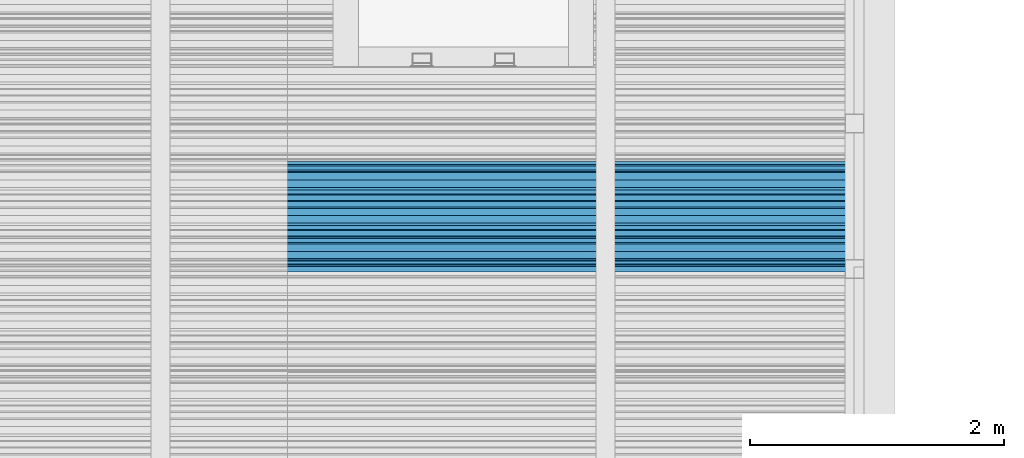
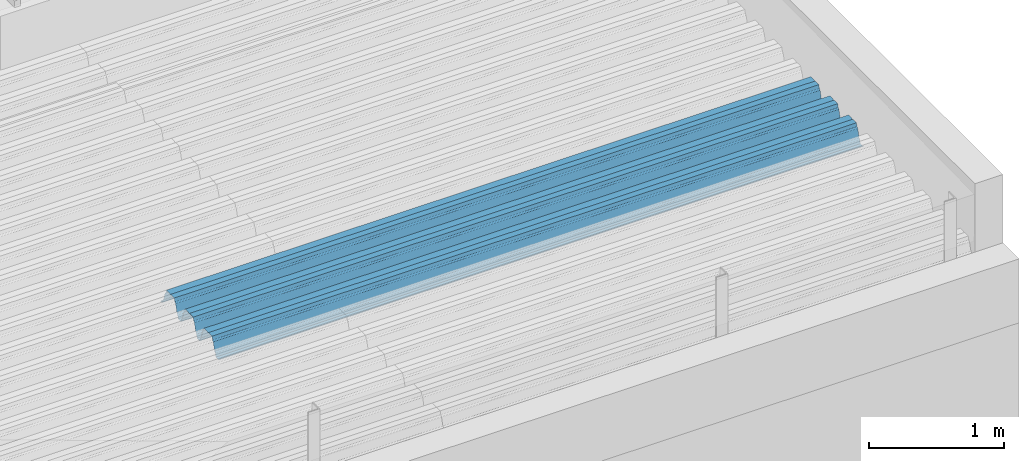
# One storey, part 39 of 153: 1 beam, 1 element without a shape of its own.
"""IFC2X3 building model written with IfcOpenShell, lengths in millimetres."""

from ifc_helpers import new_model, si_unit, frame, origin_with_axes, place, context, subcontext, project, spatial, faceted_brep, material, type_object, element, aggregate, save


model = new_model("IFC2X3")

# Units and contexts
model_context = context("Model", 3, precision=1e-05, world=origin_with_axes())
body_context = subcontext(model_context, "Body", "Model", "MODEL_VIEW")
ifc_project = project(units=[si_unit("LENGTHUNIT", "METRE", prefix="MILLI"), si_unit("AREAUNIT", "SQUARE_METRE"), si_unit("VOLUMEUNIT", "CUBIC_METRE"), si_unit("MASSUNIT", "GRAM", prefix="KILO"), si_unit("TIMEUNIT", "SECOND"), si_unit("PLANEANGLEUNIT", "RADIAN"), si_unit("SOLIDANGLEUNIT", "STERADIAN"), si_unit("THERMODYNAMICTEMPERATUREUNIT", "DEGREE_CELSIUS"), si_unit("LUMINOUSINTENSITYUNIT", "LUMEN")], contexts=[model_context])

# Site, building, storey
site_placement = place(None, origin_with_axes())
site = spatial("IfcSite", under=ifc_project, at=site_placement, CompositionType="ELEMENT")
building_placement = place(site_placement, origin_with_axes())
building = spatial("IfcBuilding", under=site, at=building_placement, CompositionType="ELEMENT")
storey_placement = place(building_placement, origin_with_axes())
storey = spatial("IfcBuildingStorey", under=building, at=storey_placement, Name="8", CompositionType="ELEMENT", Elevation=0.0)

# Assembly, beam
assembly_placement = place(storey_placement, origin_with_axes())
assembly = element("IfcElementAssembly", 1, at=assembly_placement, inside=storey, Name="Steel Assembly", AssemblyPlace="NOTDEFINED", PredefinedType="RIGID_FRAME")
ifc_material = material(Name="STEEL/S355J2")
beam_type = type_object("IfcBeamType", Name="W", PredefinedType="NOTDEFINED")
beam_placement = place(assembly_placement, frame((21782.0, 17045.0793818776, 105770.648873072), z_axis=(0.0, -0.0124990270013869, 0.999921884110963), x_axis=(-1.0, 3.00000001838171e-08, 0.0)))
beam = element("IfcBeam", 2, at=beam_placement, type_object=beam_type, material=ifc_material, ObjectType="W", context=body_context, shape_type="Brep", body=[
    faceted_brep([(0.0, -412.839996337891, -77.0100021362159), (0.0, -409.160003662109, -77.0100021362014), (5530.0, -409.160003662109, -77.0100021362014), (5530.0, -412.839996337891, -77.0100021362159), (0.0, -408.070007324222, -73.4800033569045), (5530.0, -408.070007324222, -73.4800033569045), (0.0, -400.339996337894, -48.0600013732619), (5530.0, -400.339996337894, -48.0600013732619), (0.0, -399.459991455082, -46.5600013732619), (5530.0, -399.459991455082, -46.5600013732619), (0.0, -390.329986572269, -36.5499992370314), (5530.0, -390.329986572269, -36.5499992370314), (0.0, -389.19000244141, -34.6300010680861), (5530.0, -389.19000244141, -34.6300010680861), (0.0, -367.820007324222, 35.3400001526024), (5530.0, -367.820007324222, 35.3400001526024), (0.0, -366.989990234379, 36.8499984741502), (5530.0, -366.989990234379, 36.8499984741502), (0.0, -357.809997558597, 46.8600006103807), (5530.0, -357.809997558597, 46.8600006103807), (0.0, -356.720001220707, 48.7700004577782), (5530.0, -356.720001220707, 48.7700004577782), (0.0, -349.309997558594, 73.1500015258935), (5530.0, -349.309997558594, 73.1500015258935), (0.0, -347.850006103516, 75.2300033569481), (5530.0, -347.850006103516, 75.2300033569481), (0.0, -345.470001220707, 76.010002136245), (5530.0, -345.470001220707, 76.010002136245), (0.0, -305.480010986332, 76.010002136245), (5530.0, -305.480010986332, 76.010002136245), (0.0, -304.279998779301, 75.8000030517578), (5530.0, -304.279998779301, 75.8000030517578), (0.0, -291.679992675785, 71.6999969482567), (5530.0, -291.679992675785, 71.6999969482567), (0.0, -290.179992675789, 71.2300033569481), (5530.0, -290.179992675789, 71.2300033569481), (0.0, -288.720001220707, 71.6999969482567), (5530.0, -288.720001220707, 71.6999969482567), (0.0, -276.119995117191, 75.8000030517869), (5530.0, -276.119995117191, 75.8000030517869), (0.0, -274.929992675785, 76.010002136245), (5530.0, -274.929992675785, 76.010002136245), (0.0, -234.94000244141, 76.010002136245), (5530.0, -234.94000244141, 76.010002136245), (0.0, -232.550003051758, 75.2300033569627), (5530.0, -232.550003051758, 75.2300033569627), (0.0, -231.100006103519, 73.1500015258935), (5530.0, -231.100006103519, 73.1500015258935), (0.0, -223.679992675785, 48.7700004577782), (5530.0, -223.679992675785, 48.7700004577782), (0.0, -222.589996337894, 46.8600006103661), (5530.0, -222.589996337894, 46.8600006103661), (0.0, -213.410003662113, 36.8499984741502), (5530.0, -213.410003662113, 36.8499984741502), (0.0, -212.529998779301, 35.3400001526024), (5530.0, -212.529998779301, 35.3400001526024), (0.0, -191.160003662109, -34.6300010681007), (5530.0, -191.160003662109, -34.6300010681007), (0.0, -190.070007324222, -36.5499992370605), (5530.0, -190.070007324222, -36.5499992370605), (0.0, -180.940002441406, -46.560001373291), (5530.0, -180.940002441406, -46.560001373291), (0.0, -180.059997558597, -48.0600013732619), (5530.0, -180.059997558597, -48.0600013732619), (0.0, -172.330001831055, -73.480003356919), (5530.0, -172.330001831055, -73.480003356919), (0.0, -171.240005493168, -77.0100021362159), (5530.0, -171.240005493168, -77.0100021362159), (0.0, -129.330001831062, -77.0100021362014), (5530.0, -129.330001831062, -77.0100021362014), (0.0, -128.300003051761, -73.480003356919), (5530.0, -128.300003051761, -73.480003356919), (0.0, -120.51999664307, -48.0600013732765), (5530.0, -120.51999664307, -48.0600013732765), (0.0, -119.629997253418, -46.5600013732765), (5530.0, -119.629997253418, -46.5600013732765), (0.0, -110.500000000004, -36.5499992370314), (5530.0, -110.500000000004, -36.5499992370314), (0.0, -109.419998168949, -34.6300010680861), (5530.0, -109.419998168949, -34.6300010680861), (0.0, -88.0500030517615, 35.3400001526024), (5530.0, -88.0500030517615, 35.3400001526024), (0.0, -87.160003662113, 36.8499984741356), (5530.0, -87.160003662113, 36.8499984741356), (0.0, -78.0400009155273, 46.8600006103807), (5530.0, -78.0400009155273, 46.8600006103807), (0.0, -76.8899993896557, 48.7700004577782), (5530.0, -76.8899993896557, 48.7700004577782), (0.0, -69.4800033569336, 73.1500015258935), (5530.0, -69.4800033569336, 73.1500015258935), (0.0, -68.0299987793042, 75.2300033569336), (5530.0, -68.0299987793042, 75.2300033569336), (0.0, -65.6399993896521, 76.010002136245), (5530.0, -65.6399993896521, 76.010002136245), (0.0, -25.6499996185375, 76.0100021362596), (5530.0, -25.6499996185375, 76.0100021362596), (0.0, -24.5100002288891, 75.8000030517724), (5530.0, -24.5100002288891, 75.8000030517724), (0.0, -11.8500003814697, 71.6999969482567), (5530.0, -11.8500003814697, 71.6999969482567), (0.0, -10.3999996185339, 71.2300033569481), (5530.0, -10.3999996185339, 71.2300033569481), (0.0, -8.89999961853391, 71.6999969482567), (5530.0, -8.89999961853391, 71.6999969482567), (0.0, 3.71000003814333, 75.8000030517724), (5530.0, 3.71000003814333, 75.8000030517724), (0.0, 4.90000009536379, 76.0100021362596), (5530.0, 4.90000009536379, 76.0100021362596), (0.0, 44.8899993896484, 76.010002136245), (5530.0, 44.8899993896484, 76.010002136245), (0.0, 47.2799987792932, 75.2300033569481), (5530.0, 47.2799987792932, 75.2300033569481), (0.0, 48.6800003051721, 73.1500015258935), (5530.0, 48.6800003051721, 73.1500015258935), (0.0, 56.1500015258753, 48.7700004577782), (5530.0, 56.1500015258753, 48.7700004577782), (0.0, 57.2400016784632, 46.8600006103807), (5530.0, 57.2400016784632, 46.8600006103807), (0.0, 66.3700027465784, 36.8499984741211), (5530.0, 66.3700027465784, 36.8499984741211), (0.0, 67.2499999999964, 35.3400001526024), (5530.0, 67.2499999999964, 35.3400001526024), (0.0, 88.6200027465748, -34.6300010681007), (5530.0, 88.6200027465748, -34.6300010681007), (0.0, 89.709999084469, -36.549999237046), (5530.0, 89.709999084469, -36.549999237046), (0.0, 98.8899993896412, -46.5600013732765), (5530.0, 98.8899993896412, -46.5600013732765), (0.0, 99.7699966430628, -48.0600013732765), (5530.0, 99.7699966430628, -48.0600013732765), (0.0, 107.499999999996, -73.4800033569336), (5530.0, 107.499999999996, -73.4800033569336), (0.0, 108.589996337887, -77.0100021362014), (5530.0, 108.589996337887, -77.0100021362014), (0.0, 112.269996643063, -77.0100021362159), (5530.0, 112.269996643063, -77.0100021362159), (0.0, 146.759994506836, -77.0100021362159), (5530.0, 146.759994506836, -77.0100021362159), (0.0, 150.440002441403, -77.0100021362159), (5530.0, 150.440002441403, -77.0100021362159), (0.0, 151.529998779297, -73.480003356919), (5530.0, 151.529998779297, -73.480003356919), (0.0, 159.30999755859, -48.0600013732765), (5530.0, 159.30999755859, -48.0600013732765), (0.0, 160.190002441406, -46.5600013732619), (5530.0, 160.190002441406, -46.5600013732619), (0.0, 169.320007324215, -36.549999237046), (5530.0, 169.320007324215, -36.549999237046), (0.0, 170.410003662106, -34.6300010680861), (5530.0, 170.410003662106, -34.6300010680861), (0.0, 191.779998779293, 35.3400001526024), (5530.0, 191.779998779293, 35.3400001526024), (0.0, 192.660003662109, 36.8499984741502), (5530.0, 192.660003662109, 36.8499984741502), (0.0, 201.789993286129, 46.8600006103661), (5530.0, 201.789993286129, 46.8600006103661), (0.0, 202.880004882809, 48.7700004577637), (5530.0, 202.880004882809, 48.7700004577637), (0.0, 210.350006103512, 73.150001525908), (5530.0, 210.350006103512, 73.150001525908), (0.0, 211.800003051754, 75.2300033569481), (5530.0, 211.800003051754, 75.2300033569481), (0.0, 214.190002441406, 76.010002136245), (5530.0, 214.190002441406, 76.010002136245), (0.0, 254.179992675778, 76.010002136245), (5530.0, 254.179992675778, 76.010002136245), (0.0, 255.320007324215, 75.8000030517869), (5530.0, 255.320007324215, 75.8000030517869), (0.0, 267.980010986324, 71.6999969482713), (5530.0, 267.980010986324, 71.6999969482713), (0.0, 269.429992675778, 71.2300033569481), (5530.0, 269.429992675778, 71.2300033569481), (0.0, 270.880004882809, 71.6999969482567), (5530.0, 270.880004882809, 71.6999969482567), (0.0, 283.540008544918, 75.8000030517869), (5530.0, 283.540008544918, 75.8000030517869), (0.0, 284.679992675778, 76.010002136245), (5530.0, 284.679992675778, 76.010002136245), (0.0, 324.670013427731, 76.010002136245), (5530.0, 324.670013427731, 76.010002136245), (0.0, 327.049987792969, 75.2300033569627), (5530.0, 327.049987792969, 75.2300033569627), (0.0, 328.510009765625, 73.1500015258789), (5530.0, 328.510009765625, 73.1500015258789), (0.0, 335.980010986324, 48.7700004577782), (5530.0, 335.980010986324, 48.7700004577782), (0.0, 337.05999755859, 46.8600006103661), (5530.0, 337.05999755859, 46.8600006103661), (0.0, 346.190002441399, 36.8499984741356), (5530.0, 346.190002441399, 36.8499984741356), (0.0, 347.079986572266, 35.3400001526024), (5530.0, 347.079986572266, 35.3400001526024), (0.0, 368.450012207028, -34.6300010680861), (5530.0, 368.450012207028, -34.6300010680861), (0.0, 369.529998779293, -36.5499992370314), (5530.0, 369.529998779293, -36.5499992370314), (0.0, 378.660003662106, -46.5600013732619), (5530.0, 378.660003662106, -46.5600013732619), (0.0, 379.540008544918, -48.0600013732619), (5530.0, 379.540008544918, -48.0600013732619), (0.0, 387.329986572262, -73.480003356919), (5530.0, 387.329986572262, -73.480003356919), (0.0, 388.410003662109, -77.0100021362159), (5530.0, 388.410003662109, -77.0100021362159), (0.0, 392.100006103512, -77.0100021362159), (5530.0, 392.100006103512, -77.0100021362159), (0.0, 426.589996337887, -77.0100021362159), (5530.0, 426.589996337887, -77.0100021362159), (0.0, 430.269989013668, -77.0100021362159), (5530.0, 430.269989013668, -77.0100021362159), (0.0, 431.359985351559, -73.4800033569045), (5530.0, 431.359985351559, -73.4800033569045), (0.0, 433.179992675778, -67.5699996948097), (5530.0, 433.179992675778, -67.5699996948097), (0.0, 432.220001220699, -67.2699966430373), (5530.0, 432.220001220699, -67.2699966430373), (0.0, 430.410003662106, -73.1800003051612), (5530.0, 430.410003662106, -73.1800003051612), (0.0, 429.529998779293, -76.0100021362159), (5530.0, 429.529998779293, -76.0100021362159), (0.0, 426.589996337891, -76.0100021362159), (5530.0, 426.589996337891, -76.0100021362159), (0.0, 392.100006103512, -76.0100021362159), (5530.0, 392.100006103512, -76.0100021362159), (0.0, 389.149993896481, -76.0100021362014), (5530.0, 389.149993896481, -76.0100021362014), (0.0, 388.279998779293, -73.1800003051467), (5530.0, 388.279998779293, -73.1800003051467), (0.0, 380.470001220699, -47.659999847383), (5530.0, 380.470001220699, -47.659999847383), (0.0, 379.470001220699, -45.9599990844436), (5530.0, 379.470001220699, -45.9599990844436), (0.0, 370.350006103512, -35.9599990844581), (5530.0, 370.350006103512, -35.9599990844581), (0.0, 369.369995117184, -34.2299995422218), (5530.0, 369.369995117184, -34.2299995422218), (0.0, 347.999999999996, 35.7500000000146), (5530.0, 347.999999999996, 35.7500000000146), (0.0, 346.999999999996, 37.4399986267235), (5530.0, 346.999999999996, 37.4399986267235), (0.0, 337.880004882809, 47.450000762954), (5530.0, 337.880004882809, 47.450000762954), (0.0, 336.899993896481, 49.1699981689453), (5530.0, 336.899993896481, 49.1699981689453), (0.0, 329.420013427731, 73.5999984741356), (5530.0, 329.420013427731, 73.5999984741356), (0.0, 327.679992675781, 76.0699996948533), (5530.0, 327.679992675781, 76.0699996948533), (0.0, 324.829986572262, 77.010002136245), (5530.0, 324.829986572262, 77.010002136245), (0.0, 284.589996337887, 77.010002136245), (5530.0, 284.589996337887, 77.010002136245), (0.0, 283.290008544922, 76.769996643081), (5530.0, 283.290008544922, 76.769996643081), (0.0, 270.570007324215, 72.6500015258935), (5530.0, 270.570007324215, 72.6500015258935), (0.0, 269.429992675781, 72.2799987793114), (5530.0, 269.429992675781, 72.2799987793114), (0.0, 268.279998779293, 72.650001525908), (5530.0, 268.279998779293, 72.650001525908), (0.0, 255.570007324219, 76.769996643081), (5530.0, 255.570007324219, 76.769996643081), (0.0, 254.270004272461, 77.0100021362596), (5530.0, 254.270004272461, 77.0100021362596), (0.0, 214.029998779293, 77.0100021362596), (5530.0, 214.029998779293, 77.0100021362596), (0.0, 211.179992675781, 76.0699996948388), (5530.0, 211.179992675781, 76.0699996948388), (0.0, 209.440002441403, 73.5999984741356), (5530.0, 209.440002441403, 73.5999984741356), (0.0, 201.960006713864, 49.1699981689599), (5530.0, 201.960006713864, 49.1699981689599), (0.0, 200.979995727532, 47.450000762954), (5530.0, 200.979995727532, 47.450000762954), (0.0, 191.850006103508, 37.4399986267235), (5530.0, 191.850006103508, 37.4399986267235), (0.0, 190.860000610352, 35.7500000000146), (5530.0, 190.860000610352, 35.7500000000146), (0.0, 169.49000549316, -34.2299995422218), (5530.0, 169.49000549316, -34.2299995422218), (0.0, 168.509994506832, -35.9599990844581), (5530.0, 168.509994506832, -35.9599990844581), (0.0, 159.380004882805, -45.9599990844436), (5530.0, 159.380004882805, -45.9599990844436), (0.0, 158.389999389645, -47.6599998473976), (5530.0, 158.389999389645, -47.6599998473976), (0.0, 150.580001831051, -73.1800003051612), (5530.0, 150.580001831051, -73.1800003051612), (0.0, 149.710006713864, -76.0100021362159), (5530.0, 149.710006713864, -76.0100021362159), (0.0, 146.759994506836, -76.0100021362159), (5530.0, 146.759994506836, -76.0100021362159), (0.0, 112.269996643063, -76.0100021362159), (5530.0, 112.269996643063, -76.0100021362159), (0.0, 109.319999694821, -76.0100021362159), (5530.0, 109.319999694821, -76.0100021362159), (0.0, 108.449996948239, -73.1900024413917), (5530.0, 108.449996948239, -73.1900024413917), (0.0, 100.690002441406, -47.659999847383), (5530.0, 100.690002441406, -47.659999847383), (0.0, 99.6999969482386, -45.9599990844581), (5530.0, 99.6999969482386, -45.9599990844581), (0.0, 90.5199966430664, -35.9599990844581), (5530.0, 90.5199966430664, -35.9599990844581), (0.0, 89.5400009155273, -34.2299995422218), (5530.0, 89.5400009155273, -34.2299995422218), (0.0, 68.1699981689417, 35.7500000000146), (5530.0, 68.1699981689417, 35.7500000000146), (0.0, 67.1699981689417, 37.4399986267235), (5530.0, 67.1699981689417, 37.4399986267235), (0.0, 58.0499992370569, 47.4500007629686), (5530.0, 58.0499992370569, 47.4500007629686), (0.0, 57.0699996948206, 49.1699981689599), (5530.0, 57.0699996948206, 49.1699981689599), (0.0, 49.5900001525843, 73.5899963379052), (5530.0, 49.5900001525843, 73.5899963379052), (0.0, 47.9099998474085, 76.0699996948388), (5530.0, 47.9099998474085, 76.0699996948388), (0.0, 45.0499992370569, 77.010002136245), (5530.0, 45.0499992370569, 77.010002136245), (0.0, 4.82000017165774, 77.010002136245), (5530.0, 4.82000017165774, 77.010002136245), (0.0, 3.47000002860659, 76.7699966430955), (5530.0, 3.47000002860659, 76.7699966430955), (0.0, -9.19999980926514, 72.6500015258935), (5530.0, -9.19999980926514, 72.6500015258935), (0.0, -10.3900003433264, 72.2799987792969), (5530.0, -10.3900003433264, 72.2799987792969), (0.0, -11.5399999618567, 72.6500015258935), (5530.0, -11.5399999618567, 72.6500015258935), (0.0, -24.2600002288855, 76.769996643081), (5530.0, -24.2600002288855, 76.769996643081), (0.0, -25.559999465946, 77.0100021362596), (5530.0, -25.559999465946, 77.0100021362596), (0.0, -65.8000030517615, 77.0100021362596), (5530.0, -65.8000030517615, 77.0100021362596), (0.0, -68.6500015258862, 76.0699996948533), (5530.0, -68.6500015258862, 76.0699996948533), (0.0, -70.3899993896521, 73.5999984741356), (5530.0, -70.3899993896521, 73.5999984741356), (0.0, -77.8199996948242, 49.1800003051903), (5530.0, -77.8199996948242, 49.1800003051903), (0.0, -78.8399963378943, 47.450000762954), (5530.0, -78.8399963378943, 47.450000762954), (0.0, -87.9700012207031, 37.4399986267235), (5530.0, -87.9700012207031, 37.4399986267235), (0.0, -88.9700012207068, 35.7500000000146), (5530.0, -88.9700012207068, 35.7500000000146), (0.0, -110.339996337894, -34.2299995422218), (5530.0, -110.339996337894, -34.2299995422218), (0.0, -111.319999694828, -35.9599990844581), (5530.0, -111.319999694828, -35.9599990844581), (0.0, -120.440002441406, -45.9599990844436), (5530.0, -120.440002441406, -45.9599990844436), (0.0, -121.44000244141, -47.6599998473976), (5530.0, -121.44000244141, -47.6599998473976), (0.0, -129.250000000004, -73.1900024413771), (5530.0, -129.250000000004, -73.1900024413771), (0.0, -130.080001831062, -76.0100021362159), (5530.0, -130.080001831062, -76.0100021362159), (0.0, -170.5, -76.0100021362014), (5530.0, -170.5, -76.0100021362014), (0.0, -171.380004882816, -73.1900024413917), (5530.0, -171.380004882816, -73.1900024413917), (0.0, -179.139999389652, -47.6599998473976), (5530.0, -179.139999389652, -47.6599998473976), (0.0, -180.130004882816, -45.9599990844581), (5530.0, -180.130004882816, -45.9599990844581), (0.0, -189.259994506836, -35.9599990844581), (5530.0, -189.259994506836, -35.9599990844581), (0.0, -190.240005493168, -34.2299995422218), (5530.0, -190.240005493168, -34.2299995422218), (0.0, -211.610000610355, 35.7500000000146), (5530.0, -211.610000610355, 35.7500000000146), (0.0, -212.600006103519, 37.4399986267381), (5530.0, -212.600006103519, 37.4399986267381), (0.0, -221.779998779301, 47.450000762954), (5530.0, -221.779998779301, 47.450000762954), (0.0, -222.75999450684, 49.1699981689599), (5530.0, -222.75999450684, 49.1699981689599), (0.0, -230.190002441406, 73.5999984741356), (5530.0, -230.190002441406, 73.5999984741356), (0.0, -231.919998168945, 76.0699996948388), (5530.0, -231.919998168945, 76.0699996948388), (0.0, -234.779998779301, 77.010002136245), (5530.0, -234.779998779301, 77.010002136245), (0.0, -275.010009765629, 77.010002136245), (5530.0, -275.010009765629, 77.010002136245), (0.0, -276.359985351563, 76.769996643081), (5530.0, -276.359985351563, 76.769996643081), (0.0, -289.029998779297, 72.6500015258789), (5530.0, -289.029998779297, 72.6500015258789), (0.0, -290.179992675785, 72.2799987793114), (5530.0, -290.179992675785, 72.2799987793114), (0.0, -291.380004882816, 72.650001525908), (5530.0, -291.380004882816, 72.650001525908), (0.0, -304.040008544926, 76.769996643081), (5530.0, -304.040008544926, 76.769996643081), (0.0, -305.390014648441, 77.010002136245), (5530.0, -305.390014648441, 77.010002136245), (0.0, -345.63000488282, 77.0100021362596), (5530.0, -345.63000488282, 77.0100021362596), (0.0, -348.480010986332, 76.0699996948388), (5530.0, -348.480010986332, 76.0699996948388), (0.0, -350.220001220707, 73.5999984741356), (5530.0, -350.220001220707, 73.5999984741356), (0.0, -357.649993896492, 49.1699981689599), (5530.0, -357.649993896492, 49.1699981689599), (0.0, -358.63000488282, 47.450000762954), (5530.0, -358.63000488282, 47.450000762954), (0.0, -367.809997558594, 37.4300003051903), (5530.0, -367.809997558594, 37.4300003051903), (0.0, -368.750000000004, 35.7299995422654), (5530.0, -368.750000000004, 35.7299995422654), (0.0, -390.109985351566, -34.2200012207031), (5530.0, -390.109985351566, -34.2200012207031), (0.0, -391.140014648441, -35.9500007629249), (5530.0, -391.140014648441, -35.9500007629249), (0.0, -400.269989013676, -45.9599990844436), (5530.0, -400.269989013676, -45.9599990844436), (0.0, -401.269989013672, -47.6599998473976), (5530.0, -401.269989013672, -47.6599998473976), (0.0, -409.029998779297, -73.1900024413917), (5530.0, -409.029998779297, -73.1900024413917), (0.0, -409.899993896488, -76.0100021362159), (5530.0, -409.899993896488, -76.0100021362159), (0.0, -412.839996337891, -76.0100021362159), (5530.0, -412.839996337891, -76.0100021362159), (0.0, -433.179992675785, -76.0100021362159), (5530.0, -433.179992675785, -76.0100021362159), (0.0, -433.179992675785, -77.0100021362159), (5530.0, -433.179992675785, -77.0100021362159)], [[[0, 1, 2, 3]], [[1, 4, 5, 2]], [[4, 6, 7, 5]], [[6, 8, 9, 7]], [[8, 10, 11, 9]], [[10, 12, 13, 11]], [[12, 14, 15, 13]], [[14, 16, 17, 15]], [[16, 18, 19, 17]], [[18, 20, 21, 19]], [[20, 22, 23, 21]], [[22, 24, 25, 23]], [[24, 26, 27, 25]], [[26, 28, 29, 27]], [[28, 30, 31, 29]], [[30, 32, 33, 31]], [[32, 34, 35, 33]], [[34, 36, 37, 35]], [[36, 38, 39, 37]], [[38, 40, 41, 39]], [[40, 42, 43, 41]], [[42, 44, 45, 43]], [[44, 46, 47, 45]], [[46, 48, 49, 47]], [[48, 50, 51, 49]], [[50, 52, 53, 51]], [[52, 54, 55, 53]], [[54, 56, 57, 55]], [[56, 58, 59, 57]], [[58, 60, 61, 59]], [[60, 62, 63, 61]], [[62, 64, 65, 63]], [[64, 66, 67, 65]], [[66, 68, 69, 67]], [[68, 70, 71, 69]], [[70, 72, 73, 71]], [[72, 74, 75, 73]], [[74, 76, 77, 75]], [[76, 78, 79, 77]], [[78, 80, 81, 79]], [[80, 82, 83, 81]], [[82, 84, 85, 83]], [[84, 86, 87, 85]], [[86, 88, 89, 87]], [[88, 90, 91, 89]], [[90, 92, 93, 91]], [[92, 94, 95, 93]], [[94, 96, 97, 95]], [[96, 98, 99, 97]], [[98, 100, 101, 99]], [[100, 102, 103, 101]], [[102, 104, 105, 103]], [[104, 106, 107, 105]], [[106, 108, 109, 107]], [[108, 110, 111, 109]], [[110, 112, 113, 111]], [[112, 114, 115, 113]], [[114, 116, 117, 115]], [[116, 118, 119, 117]], [[118, 120, 121, 119]], [[120, 122, 123, 121]], [[122, 124, 125, 123]], [[124, 126, 127, 125]], [[126, 128, 129, 127]], [[128, 130, 131, 129]], [[130, 132, 133, 131]], [[132, 134, 135, 133]], [[134, 136, 137, 135]], [[136, 138, 139, 137]], [[138, 140, 141, 139]], [[140, 142, 143, 141]], [[142, 144, 145, 143]], [[144, 146, 147, 145]], [[146, 148, 149, 147]], [[148, 150, 151, 149]], [[150, 152, 153, 151]], [[152, 154, 155, 153]], [[154, 156, 157, 155]], [[156, 158, 159, 157]], [[158, 160, 161, 159]], [[160, 162, 163, 161]], [[162, 164, 165, 163]], [[164, 166, 167, 165]], [[166, 168, 169, 167]], [[168, 170, 171, 169]], [[170, 172, 173, 171]], [[172, 174, 175, 173]], [[174, 176, 177, 175]], [[176, 178, 179, 177]], [[178, 180, 181, 179]], [[180, 182, 183, 181]], [[182, 184, 185, 183]], [[184, 186, 187, 185]], [[186, 188, 189, 187]], [[188, 190, 191, 189]], [[190, 192, 193, 191]], [[192, 194, 195, 193]], [[194, 196, 197, 195]], [[196, 198, 199, 197]], [[198, 200, 201, 199]], [[200, 202, 203, 201]], [[202, 204, 205, 203]], [[204, 206, 207, 205]], [[206, 208, 209, 207]], [[208, 210, 211, 209]], [[210, 212, 213, 211]], [[212, 214, 215, 213]], [[214, 216, 217, 215]], [[216, 218, 219, 217]], [[218, 220, 221, 219]], [[220, 222, 223, 221]], [[222, 224, 225, 223]], [[224, 226, 227, 225]], [[226, 228, 229, 227]], [[228, 230, 231, 229]], [[230, 232, 233, 231]], [[232, 234, 235, 233]], [[234, 236, 237, 235]], [[236, 238, 239, 237]], [[238, 240, 241, 239]], [[240, 242, 243, 241]], [[242, 244, 245, 243]], [[244, 246, 247, 245]], [[246, 248, 249, 247]], [[248, 250, 251, 249]], [[250, 252, 253, 251]], [[252, 254, 255, 253]], [[254, 256, 257, 255]], [[256, 258, 259, 257]], [[258, 260, 261, 259]], [[260, 262, 263, 261]], [[262, 264, 265, 263]], [[264, 266, 267, 265]], [[266, 268, 269, 267]], [[268, 270, 271, 269]], [[270, 272, 273, 271]], [[272, 274, 275, 273]], [[274, 276, 277, 275]], [[276, 278, 279, 277]], [[278, 280, 281, 279]], [[280, 282, 283, 281]], [[282, 284, 285, 283]], [[284, 286, 287, 285]], [[286, 288, 289, 287]], [[288, 290, 291, 289]], [[290, 292, 293, 291]], [[292, 294, 295, 293]], [[294, 296, 297, 295]], [[296, 298, 299, 297]], [[298, 300, 301, 299]], [[300, 302, 303, 301]], [[302, 304, 305, 303]], [[304, 306, 307, 305]], [[306, 308, 309, 307]], [[308, 310, 311, 309]], [[310, 312, 313, 311]], [[312, 314, 315, 313]], [[314, 316, 317, 315]], [[316, 318, 319, 317]], [[318, 320, 321, 319]], [[320, 322, 323, 321]], [[322, 324, 325, 323]], [[324, 326, 327, 325]], [[326, 328, 329, 327]], [[328, 330, 331, 329]], [[330, 332, 333, 331]], [[332, 334, 335, 333]], [[334, 336, 337, 335]], [[336, 338, 339, 337]], [[338, 340, 341, 339]], [[340, 342, 343, 341]], [[342, 344, 345, 343]], [[344, 346, 347, 345]], [[346, 348, 349, 347]], [[348, 350, 351, 349]], [[350, 352, 353, 351]], [[352, 354, 355, 353]], [[354, 356, 357, 355]], [[356, 358, 359, 357]], [[358, 360, 361, 359]], [[360, 362, 363, 361]], [[362, 364, 365, 363]], [[364, 366, 367, 365]], [[366, 368, 369, 367]], [[368, 370, 371, 369]], [[370, 372, 373, 371]], [[372, 374, 375, 373]], [[374, 376, 377, 375]], [[376, 378, 379, 377]], [[378, 380, 381, 379]], [[380, 382, 383, 381]], [[382, 384, 385, 383]], [[384, 386, 387, 385]], [[386, 388, 389, 387]], [[388, 390, 391, 389]], [[390, 392, 393, 391]], [[392, 394, 395, 393]], [[394, 396, 397, 395]], [[396, 398, 399, 397]], [[398, 400, 401, 399]], [[400, 402, 403, 401]], [[402, 404, 405, 403]], [[404, 406, 407, 405]], [[406, 408, 409, 407]], [[408, 410, 411, 409]], [[410, 412, 413, 411]], [[412, 414, 415, 413]], [[414, 416, 417, 415]], [[416, 418, 419, 417]], [[418, 420, 421, 419]], [[420, 422, 423, 421]], [[422, 424, 425, 423]], [[424, 426, 427, 425]], [[426, 428, 429, 427]], [[428, 430, 431, 429]], [[430, 0, 3, 431]], [[5, 7, 9, 11, 13, 15, 17, 19, 21, 23, 25, 27, 29, 31, 33, 35, 37, 39, 41, 43, 45, 47, 49, 51, 53, 55, 57, 59, 61, 63, 65, 67, 69, 71, 73, 75, 77, 79, 81, 83, 85, 87, 89, 91, 93, 95, 97, 99, 101, 103, 105, 107, 109, 111, 113, 115, 117, 119, 121, 123, 125, 127, 129, 131, 133, 135, 137, 139, 141, 143, 145, 147, 149, 151, 153, 155, 157, 159, 161, 163, 165, 167, 169, 171, 173, 175, 177, 179, 181, 183, 185, 187, 189, 191, 193, 195, 197, 199, 201, 203, 205, 207, 209, 211, 213, 215, 217, 219, 221, 223, 225, 227, 229, 231, 233, 235, 237, 239, 241, 243, 245, 247, 249, 251, 253, 255, 257, 259, 261, 263, 265, 267, 269, 271, 273, 275, 277, 279, 281, 283, 285, 287, 289, 291, 293, 295, 297, 299, 301, 303, 305, 307, 309, 311, 313, 315, 317, 319, 321, 323, 325, 327, 329, 331, 333, 335, 337, 339, 341, 343, 345, 347, 349, 351, 353, 355, 357, 359, 361, 363, 365, 367, 369, 371, 373, 375, 377, 379, 381, 383, 385, 387, 389, 391, 393, 395, 397, 399, 401, 403, 405, 407, 409, 411, 413, 415, 417, 419, 421, 423, 425, 427, 429, 431, 3, 2]], [[430, 428, 426, 424, 422, 420, 418, 416, 414, 412, 410, 408, 406, 404, 402, 400, 398, 396, 394, 392, 390, 388, 386, 384, 382, 380, 378, 376, 374, 372, 370, 368, 366, 364, 362, 360, 358, 356, 354, 352, 350, 348, 346, 344, 342, 340, 338, 336, 334, 332, 330, 328, 326, 324, 322, 320, 318, 316, 314, 312, 310, 308, 306, 304, 302, 300, 298, 296, 294, 292, 290, 288, 286, 284, 282, 280, 278, 276, 274, 272, 270, 268, 266, 264, 262, 260, 258, 256, 254, 252, 250, 248, 246, 244, 242, 240, 238, 236, 234, 232, 230, 228, 226, 224, 222, 220, 218, 216, 214, 212, 210, 208, 206, 204, 202, 200, 198, 196, 194, 192, 190, 188, 186, 184, 182, 180, 178, 176, 174, 172, 170, 168, 166, 164, 162, 160, 158, 156, 154, 152, 150, 148, 146, 144, 142, 140, 138, 136, 134, 132, 130, 128, 126, 124, 122, 120, 118, 116, 114, 112, 110, 108, 106, 104, 102, 100, 98, 96, 94, 92, 90, 88, 86, 84, 82, 80, 78, 76, 74, 72, 70, 68, 66, 64, 62, 60, 58, 56, 54, 52, 50, 48, 46, 44, 42, 40, 38, 36, 34, 32, 30, 28, 26, 24, 22, 20, 18, 16, 14, 12, 10, 8, 6, 4, 1, 0]]]),
])
aggregate(assembly, [beam])

save(model, "model.ifc")
